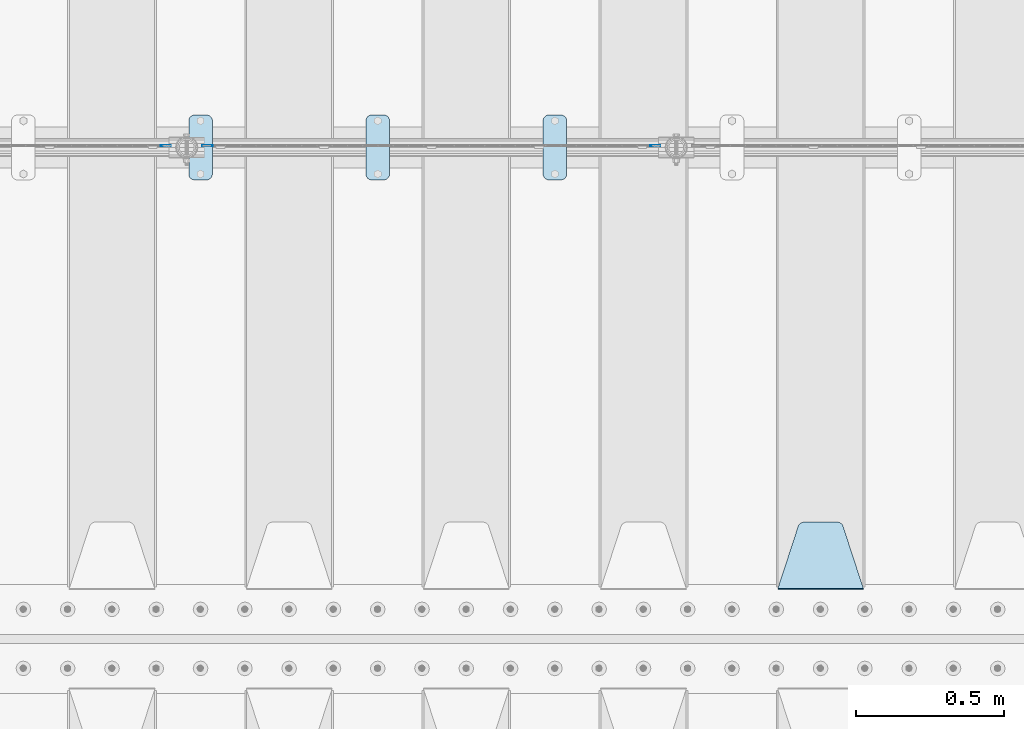
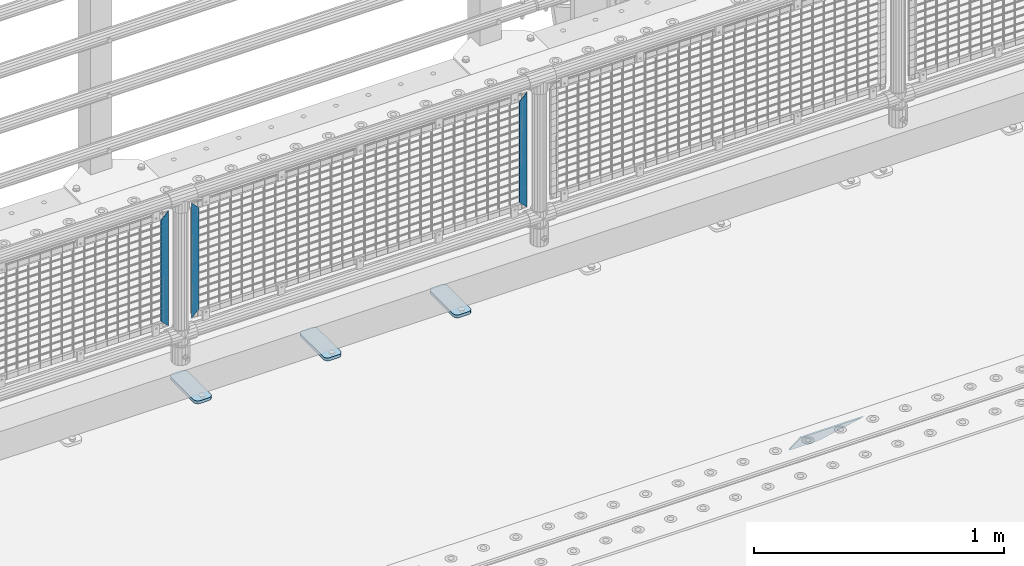
# One storey, part 172 of 193: 7 plates.
"""IFC2X3 building model written with IfcOpenShell, lengths in millimetres."""

from ifc_helpers import new_model, si_unit, frame, origin_with_axes, place, context, subcontext, project, spatial, faceted_brep, material, type_object, element, save


model = new_model("IFC2X3")

# Units and contexts
model_context = context("Model", 3, precision=1e-05, world=origin_with_axes())
body_context = subcontext(model_context, "Body", "Model", "MODEL_VIEW")
ifc_project = project(units=[si_unit("LENGTHUNIT", "METRE", prefix="MILLI"), si_unit("AREAUNIT", "SQUARE_METRE"), si_unit("VOLUMEUNIT", "CUBIC_METRE"), si_unit("MASSUNIT", "GRAM", prefix="KILO"), si_unit("TIMEUNIT", "SECOND"), si_unit("PLANEANGLEUNIT", "RADIAN"), si_unit("SOLIDANGLEUNIT", "STERADIAN"), si_unit("THERMODYNAMICTEMPERATUREUNIT", "DEGREE_CELSIUS"), si_unit("LUMINOUSINTENSITYUNIT", "LUMEN")], contexts=[model_context])

# Site, building, storey
site_placement = place(None, origin_with_axes())
site = spatial("IfcSite", under=ifc_project, at=site_placement, CompositionType="ELEMENT")
building_placement = place(site_placement, origin_with_axes())
building = spatial("IfcBuilding", under=site, at=building_placement, Name="Standard", CompositionType="ELEMENT")
storey_placement = place(building_placement, origin_with_axes())
storey = spatial("IfcBuildingStorey", under=building, at=storey_placement, Name="Undefined", CompositionType="ELEMENT", Elevation=0.0)

# Plates
ifc_material_1 = material(Name="STEEL/S355N")
plate_type_1 = type_object("IfcPlateType", PredefinedType="NOTDEFINED")
plate_1_placement = place(storey_placement, frame((-32905.0, 27168.232233047, -1.76776695296758), z_axis=(0.0, 0.707106781186547, -0.707106781186548), x_axis=(-1.0, 0.0, 0.0)))
element("IfcPlate", 1, at=plate_1_placement, inside=storey, type_object=plate_type_1, material=ifc_material_1, context=body_context, shape_type="Brep", body=[
    faceted_brep([(0.0, -2.5, 0.0), (69.345504679477, -2.50000000000364, 300.171731424831), (69.345504679477, 2.49999999999636, 300.171731424831), (0.0, 2.5, 0.0), (70.9274061199576, -2.50000000000364, 304.897442415397), (70.9274061199576, 2.49999999999636, 304.897442415397), (73.3818627772307, -2.50000000000364, 309.234538108529), (73.3818627772307, 2.49999999999636, 309.234538108529), (76.6187032999551, -2.50000000000728, 313.023683126103), (76.6187032999551, 2.49999999999636, 313.023683126103), (80.5190132704993, -2.50000000000364, 316.125672595372), (80.5190132704993, 2.49999999999636, 316.125672595368), (84.9395038596849, -2.50000000000364, 318.426546230472), (84.9395038596849, 2.49999999999636, 318.426546230476), (89.7177759439219, -2.50000000000364, 319.841774983273), (89.7177759439219, 2.49999999999636, 319.841774983277), (94.678286292652, -2.50000000000364, 320.319366455074), (94.678286292652, 2.49999999999636, 320.319366455074), (195.321713707348, -2.50000000000364, 320.319366455074), (195.321713707348, 2.49999999999636, 320.319366455074), (200.282224056078, -2.50000000000364, 319.841774983273), (200.282224056078, 2.49999999999636, 319.841774983277), (205.060496140315, -2.50000000000364, 318.426546230472), (205.060496140315, 2.49999999999636, 318.426546230472), (209.480986729501, -2.50000000000364, 316.125672595372), (209.480986729501, 2.49999999999636, 316.125672595368), (213.381296700045, -2.50000000000728, 313.023683126103), (213.381296700045, 2.49999999999272, 313.023683126103), (216.618137222769, -2.50000000000364, 309.234538108525), (216.618137222769, 2.49999999999636, 309.234538108522), (219.072593880042, -2.50000000000364, 304.897442415397), (219.072593880042, 2.49999999999636, 304.897442415397), (220.654495320523, -2.50000000000364, 300.171731424831), (220.654495320523, 2.49999999999636, 300.171731424831), (290.0, -2.50000000000364, 0.0), (290.0, 2.49999999999636, 0.0)], [[[0, 1, 2, 3]], [[1, 4, 5, 2]], [[4, 6, 7, 5]], [[6, 8, 9, 7]], [[8, 10, 11, 9]], [[10, 12, 13, 11]], [[12, 14, 15, 13]], [[14, 16, 17, 15]], [[16, 18, 19, 17]], [[18, 20, 21, 19]], [[20, 22, 23, 21]], [[22, 24, 25, 23]], [[24, 26, 27, 25]], [[26, 28, 29, 27]], [[28, 30, 31, 29]], [[30, 32, 33, 31]], [[32, 34, 35, 33]], [[34, 0, 3, 35]], [[5, 7, 9, 11, 13, 15, 17, 19, 21, 23, 25, 27, 29, 31, 33, 35, 3, 2]], [[34, 32, 30, 28, 26, 24, 22, 20, 18, 16, 14, 12, 10, 8, 6, 4, 1, 0]]]),
])
ifc_material_2 = material(Name="Misc_Undefined")
plate_type_2 = type_object("IfcPlateType", PredefinedType="NOTDEFINED")
plate_2_placement = place(storey_placement, frame((-35108.490286459, 28670.5, 879.519963133601), z_axis=(-0.707008801899319, 0.0, -0.707204746899291), x_axis=(-0.70720474689929, 0.0, 0.707008801899319)))
element("IfcPlate", 2, at=plate_2_placement, inside=storey, type_object=plate_type_2, material=ifc_material_2, context=body_context, shape_type="Brep", body=[
    faceted_brep([(0.0, -1.49999999999636, 3.63797880709171e-12), (-348.552185058594, -1.5, 348.655029296875), (-348.552185058594, 1.5, 348.655029296875), (0.0, 1.50000000000364, 7.27595761418343e-12), (-348.544891357422, -1.5, 398.152496337891), (-348.544891357422, 1.5, 398.152496337891), (49.50439453125, -1.5, 7.6397554948926e-11), (49.50439453125, 1.5, 7.6397554948926e-11)], [[[0, 1, 2, 3]], [[1, 4, 5, 2]], [[4, 6, 7, 5]], [[6, 0, 3, 7]], [[5, 7, 3, 2]], [[6, 4, 1, 0]]]),
])
for number, where, z_axis, x_axis in (
    (3, (-33627.5003125164, 28670.5, 879.52), (0.707103624179499, 0.0, -0.707109938179501), (0.707109938179495, 0.0, 0.707103624179505)),
    (4, (-35285.5003125164, 28670.5, 879.52), (0.707103624179499, 0.0, -0.707109938179501), (0.707109938179495, 0.0, 0.707103624179505)),
):
    element("IfcPlate", number, at=place(storey_placement, frame(where, z_axis=z_axis, x_axis=x_axis)), inside=storey, type_object=plate_type_2, material=ifc_material_2, context=body_context, shape_type="Brep", body=[
        faceted_brep([(0.0, -1.49999999999636, 3.63797880709171e-12), (-348.605163574215, -1.5, 348.602081298824), (-348.605163574215, 1.5, 348.602081298824), (0.0, 1.50000000000364, 7.27595761418343e-12), (-348.605163574215, -1.5, 398.099334716793), (-348.605163574215, 1.5, 398.099334716793), (49.4976959228552, -1.5, -1.01863406598568e-10), (49.4976959228552, 1.5, -1.01863406598568e-10)], [[[0, 1, 2, 3]], [[1, 4, 5, 2]], [[4, 6, 7, 5]], [[6, 0, 3, 7]], [[5, 7, 3, 2]], [[6, 4, 1, 0]]]),
    ])
ifc_material_3 = material(Name="STEEL/S355J2")
plate_type_3 = type_object("IfcPlateType", PredefinedType="NOTDEFINED")
plate_3_placement = place(storey_placement, frame((-33990.0, 28774.5, 21.0199999999977), z_axis=(1.0, 0.0, 0.0), x_axis=(0.0, -1.0, 0.0)))
element("IfcPlate", 5, at=plate_3_placement, inside=storey, type_object=plate_type_3, material=ifc_material_3, context=body_context, shape_type="Brep", body=[
    faceted_brep([(0.0, -7.0, 20.0), (0.0, -7.0, 60.0), (0.0, 7.0, 60.0), (0.0, 7.0, 20.0), (0.384294391937146, -7.0, 63.9018064403208), (0.384294391937146, 7.0, 63.9018064403208), (1.52240934977453, -7.0, 67.6536686473009), (1.52240934977453, 7.0, 67.6536686473009), (3.37060775395003, -7.0, 71.1114046603907), (3.37060775395003, 7.0, 71.1114046603907), (5.8578643762703, -7.0, 74.1421356237297), (5.8578643762703, 7.0, 74.1421356237297), (8.88859533960931, -7.0, 76.62939224605), (8.88859533960931, 7.0, 76.62939224605), (12.3463313526991, -7.0, 78.4775906502255), (12.3463313526991, 7.0, 78.4775906502255), (16.0981935596792, -7.0, 79.6157056080629), (16.0981935596792, 7.0, 79.6157056080629), (20.0, -7.0, 80.0), (20.0, 7.0, 80.0), (200.0, -7.0, 80.0), (200.0, 7.0, 80.0), (203.901806440321, -7.0, 79.6157056080629), (203.901806440321, 7.0, 79.6157056080629), (207.653668647301, -7.0, 78.4775906502255), (207.653668647301, 7.0, 78.4775906502255), (211.111404660391, -7.0, 76.62939224605), (211.111404660391, 7.0, 76.62939224605), (214.14213562373, -7.0, 74.1421356237297), (214.14213562373, 7.0, 74.1421356237297), (216.62939224605, -7.0, 71.1114046603907), (216.62939224605, 7.0, 71.1114046603907), (218.477590650225, -7.0, 67.6536686473009), (218.477590650225, 7.0, 67.6536686473009), (219.615705608063, -7.0, 63.9018064403208), (219.615705608063, 7.0, 63.9018064403208), (220.0, -7.0, 60.0), (220.0, 7.0, 60.0), (220.0, -7.0, 20.0), (220.0, 7.0, 20.0), (219.615705608063, -7.0, 16.0981935596792), (219.615705608063, 7.0, 16.0981935596792), (218.477590650225, -7.0, 12.3463313526991), (218.477590650225, 7.0, 12.3463313526991), (216.62939224605, -7.0, 8.88859533960931), (216.62939224605, 7.0, 8.88859533960931), (214.14213562373, -7.0, 5.8578643762703), (214.14213562373, 7.0, 5.8578643762703), (211.111404660391, -7.0, 3.37060775395003), (211.111404660391, 7.0, 3.37060775395003), (207.653668647301, -7.0, 1.52240934977453), (207.653668647301, 7.0, 1.52240934977453), (203.901806440321, -7.0, 0.384294391937146), (203.901806440321, 7.0, 0.384294391937146), (200.0, -7.0, 0.0), (200.0, 7.0, 0.0), (20.0, -7.0, 0.0), (20.0, 7.0, 0.0), (16.0981935596792, -7.0, 0.384294391937146), (16.0981935596792, 7.0, 0.384294391937146), (12.3463313526991, -7.0, 1.52240934977453), (12.3463313526991, 7.0, 1.52240934977453), (8.88859533960931, -7.0, 3.37060775395003), (8.88859533960931, 7.0, 3.37060775395003), (5.8578643762703, -7.0, 5.8578643762703), (5.8578643762703, 7.0, 5.8578643762703), (3.37060775395003, -7.0, 8.88859533960931), (3.37060775395003, 7.0, 8.88859533960931), (1.52240934977453, -7.0, 12.3463313526991), (1.52240934977453, 7.0, 12.3463313526991), (0.384294391937146, -7.0, 16.0981935596792), (0.384294391937146, 7.0, 16.0981935596792)], [[[0, 1, 2, 3]], [[1, 4, 5, 2]], [[4, 6, 7, 5]], [[6, 8, 9, 7]], [[8, 10, 11, 9]], [[10, 12, 13, 11]], [[12, 14, 15, 13]], [[14, 16, 17, 15]], [[16, 18, 19, 17]], [[18, 20, 21, 19]], [[20, 22, 23, 21]], [[22, 24, 25, 23]], [[24, 26, 27, 25]], [[26, 28, 29, 27]], [[28, 30, 31, 29]], [[30, 32, 33, 31]], [[32, 34, 35, 33]], [[34, 36, 37, 35]], [[36, 38, 39, 37]], [[38, 40, 41, 39]], [[40, 42, 43, 41]], [[42, 44, 45, 43]], [[44, 46, 47, 45]], [[46, 48, 49, 47]], [[48, 50, 51, 49]], [[50, 52, 53, 51]], [[52, 54, 55, 53]], [[54, 56, 57, 55]], [[56, 58, 59, 57]], [[58, 60, 61, 59]], [[60, 62, 63, 61]], [[62, 64, 65, 63]], [[64, 66, 67, 65]], [[66, 68, 69, 67]], [[68, 70, 71, 69]], [[70, 0, 3, 71]], [[5, 7, 9, 11, 13, 15, 17, 19, 21, 23, 25, 27, 29, 31, 33, 35, 37, 39, 41, 43, 45, 47, 49, 51, 53, 55, 57, 59, 61, 63, 65, 67, 69, 71, 3, 2]], [[70, 68, 66, 64, 62, 60, 58, 56, 54, 52, 50, 48, 46, 44, 42, 40, 38, 36, 34, 32, 30, 28, 26, 24, 22, 20, 18, 16, 14, 12, 10, 8, 6, 4, 1, 0]]]),
])
plate_4_placement = place(storey_placement, frame((-34590.0, 28774.5, 21.0199999999977), z_axis=(1.0, 0.0, 0.0), x_axis=(0.0, -1.0, 0.0)))
element("IfcPlate", 6, at=plate_4_placement, inside=storey, type_object=plate_type_3, material=ifc_material_3, context=body_context, shape_type="Brep", body=[
    faceted_brep([(0.0, -7.0, 20.0), (0.0, -7.0, 60.0), (0.0, 7.0, 60.0), (0.0, 7.0, 20.0), (0.384294391937146, -7.0, 63.9018064403208), (0.384294391937146, 7.0, 63.9018064403208), (1.52240934977453, -7.0, 67.6536686473009), (1.52240934977453, 7.0, 67.6536686473009), (3.37060775395003, -7.0, 71.1114046603907), (3.37060775395003, 7.0, 71.1114046603907), (5.8578643762703, -7.0, 74.1421356237297), (5.8578643762703, 7.0, 74.1421356237297), (8.88859533960931, -7.0, 76.62939224605), (8.88859533960931, 7.0, 76.62939224605), (12.3463313526991, -7.0, 78.4775906502255), (12.3463313526991, 7.0, 78.4775906502255), (16.0981935596792, -7.0, 79.6157056080629), (16.0981935596792, 7.0, 79.6157056080629), (20.0, -7.0, 80.0), (20.0, 7.0, 80.0), (200.0, -7.0, 80.0), (200.0, 7.0, 80.0), (203.901806440321, -7.0, 79.6157056080629), (203.901806440321, 7.0, 79.6157056080629), (207.653668647301, -7.0, 78.4775906502255), (207.653668647301, 7.0, 78.4775906502255), (211.111404660391, -7.0, 76.62939224605), (211.111404660391, 7.0, 76.62939224605), (214.14213562373, -7.0, 74.1421356237297), (214.14213562373, 7.0, 74.1421356237297), (216.62939224605, -7.0, 71.1114046603907), (216.62939224605, 7.0, 71.1114046603907), (218.477590650225, -7.0, 67.6536686473009), (218.477590650225, 7.0, 67.6536686473009), (219.615705608063, -7.0, 63.9018064403208), (219.615705608063, 7.0, 63.9018064403208), (220.0, -7.0, 60.0), (220.0, 7.0, 60.0), (220.0, -7.0, 20.0), (220.0, 7.0, 20.0), (219.615705608063, -7.0, 16.0981935596792), (219.615705608063, 7.0, 16.0981935596792), (218.477590650225, -7.0, 12.3463313526991), (218.477590650225, 7.0, 12.3463313526991), (216.62939224605, -7.0, 8.88859533960931), (216.62939224605, 7.0, 8.88859533960931), (214.14213562373, -7.0, 5.8578643762703), (214.14213562373, 7.0, 5.8578643762703), (211.111404660391, -7.0, 3.37060775395003), (211.111404660391, 7.0, 3.37060775395003), (207.653668647301, -7.0, 1.52240934977453), (207.653668647301, 7.0, 1.52240934977453), (203.901806440321, -7.0, 0.384294391937146), (203.901806440321, 7.0, 0.384294391937146), (200.0, -7.0, 0.0), (200.0, 7.0, 0.0), (20.0, -7.0, 0.0), (20.0, 7.0, 0.0), (16.0981935596792, -7.0, 0.384294391937146), (16.0981935596792, 7.0, 0.384294391937146), (12.3463313526991, -7.0, 1.52240934977453), (12.3463313526991, 7.0, 1.52240934977453), (8.88859533960931, -7.0, 3.37060775395003), (8.88859533960931, 7.0, 3.37060775395003), (5.8578643762703, -7.0, 5.8578643762703), (5.8578643762703, 7.0, 5.8578643762703), (3.37060775395003, -7.0, 8.88859533960931), (3.37060775395003, 7.0, 8.88859533960931), (1.52240934977453, -7.0, 12.3463313526991), (1.52240934977453, 7.0, 12.3463313526991), (0.384294391937146, -7.0, 16.0981935596792), (0.384294391937146, 7.0, 16.0981935596792)], [[[0, 1, 2, 3]], [[1, 4, 5, 2]], [[4, 6, 7, 5]], [[6, 8, 9, 7]], [[8, 10, 11, 9]], [[10, 12, 13, 11]], [[12, 14, 15, 13]], [[14, 16, 17, 15]], [[16, 18, 19, 17]], [[18, 20, 21, 19]], [[20, 22, 23, 21]], [[22, 24, 25, 23]], [[24, 26, 27, 25]], [[26, 28, 29, 27]], [[28, 30, 31, 29]], [[30, 32, 33, 31]], [[32, 34, 35, 33]], [[34, 36, 37, 35]], [[36, 38, 39, 37]], [[38, 40, 41, 39]], [[40, 42, 43, 41]], [[42, 44, 45, 43]], [[44, 46, 47, 45]], [[46, 48, 49, 47]], [[48, 50, 51, 49]], [[50, 52, 53, 51]], [[52, 54, 55, 53]], [[54, 56, 57, 55]], [[56, 58, 59, 57]], [[58, 60, 61, 59]], [[60, 62, 63, 61]], [[62, 64, 65, 63]], [[64, 66, 67, 65]], [[66, 68, 69, 67]], [[68, 70, 71, 69]], [[70, 0, 3, 71]], [[5, 7, 9, 11, 13, 15, 17, 19, 21, 23, 25, 27, 29, 31, 33, 35, 37, 39, 41, 43, 45, 47, 49, 51, 53, 55, 57, 59, 61, 63, 65, 67, 69, 71, 3, 2]], [[70, 68, 66, 64, 62, 60, 58, 56, 54, 52, 50, 48, 46, 44, 42, 40, 38, 36, 34, 32, 30, 28, 26, 24, 22, 20, 18, 16, 14, 12, 10, 8, 6, 4, 1, 0]]]),
])
plate_5_placement = place(storey_placement, frame((-35190.0, 28774.5, 21.0199999999977), z_axis=(1.0, 0.0, 0.0), x_axis=(0.0, -1.0, 0.0)))
element("IfcPlate", 7, at=plate_5_placement, inside=storey, type_object=plate_type_3, material=ifc_material_3, context=body_context, shape_type="Brep", body=[
    faceted_brep([(0.0, -7.0, 20.0), (0.0, -7.0, 60.0), (0.0, 7.0, 60.0), (0.0, 7.0, 20.0), (0.384294391937146, -7.0, 63.9018064403208), (0.384294391937146, 7.0, 63.9018064403208), (1.52240934977453, -7.0, 67.6536686473009), (1.52240934977453, 7.0, 67.6536686473009), (3.37060775395003, -7.0, 71.1114046603907), (3.37060775395003, 7.0, 71.1114046603907), (5.8578643762703, -7.0, 74.1421356237297), (5.8578643762703, 7.0, 74.1421356237297), (8.88859533960931, -7.0, 76.62939224605), (8.88859533960931, 7.0, 76.62939224605), (12.3463313526991, -7.0, 78.4775906502255), (12.3463313526991, 7.0, 78.4775906502255), (16.0981935596792, -7.0, 79.6157056080629), (16.0981935596792, 7.0, 79.6157056080629), (20.0, -7.0, 80.0), (20.0, 7.0, 80.0), (200.0, -7.0, 80.0), (200.0, 7.0, 80.0), (203.901806440321, -7.0, 79.6157056080629), (203.901806440321, 7.0, 79.6157056080629), (207.653668647301, -7.0, 78.4775906502255), (207.653668647301, 7.0, 78.4775906502255), (211.111404660391, -7.0, 76.62939224605), (211.111404660391, 7.0, 76.62939224605), (214.14213562373, -7.0, 74.1421356237297), (214.14213562373, 7.0, 74.1421356237297), (216.62939224605, -7.0, 71.1114046603907), (216.62939224605, 7.0, 71.1114046603907), (218.477590650225, -7.0, 67.6536686473009), (218.477590650225, 7.0, 67.6536686473009), (219.615705608063, -7.0, 63.9018064403208), (219.615705608063, 7.0, 63.9018064403208), (220.0, -7.0, 60.0), (220.0, 7.0, 60.0), (220.0, -7.0, 20.0), (220.0, 7.0, 20.0), (219.615705608063, -7.0, 16.0981935596792), (219.615705608063, 7.0, 16.0981935596792), (218.477590650225, -7.0, 12.3463313526991), (218.477590650225, 7.0, 12.3463313526991), (216.62939224605, -7.0, 8.88859533960931), (216.62939224605, 7.0, 8.88859533960931), (214.14213562373, -7.0, 5.8578643762703), (214.14213562373, 7.0, 5.8578643762703), (211.111404660391, -7.0, 3.37060775395003), (211.111404660391, 7.0, 3.37060775395003), (207.653668647301, -7.0, 1.52240934977453), (207.653668647301, 7.0, 1.52240934977453), (203.901806440321, -7.0, 0.384294391937146), (203.901806440321, 7.0, 0.384294391937146), (200.0, -7.0, 0.0), (200.0, 7.0, 0.0), (20.0, -7.0, 0.0), (20.0, 7.0, 0.0), (16.0981935596792, -7.0, 0.384294391937146), (16.0981935596792, 7.0, 0.384294391937146), (12.3463313526991, -7.0, 1.52240934977453), (12.3463313526991, 7.0, 1.52240934977453), (8.88859533960931, -7.0, 3.37060775395003), (8.88859533960931, 7.0, 3.37060775395003), (5.8578643762703, -7.0, 5.8578643762703), (5.8578643762703, 7.0, 5.8578643762703), (3.37060775395003, -7.0, 8.88859533960931), (3.37060775395003, 7.0, 8.88859533960931), (1.52240934977453, -7.0, 12.3463313526991), (1.52240934977453, 7.0, 12.3463313526991), (0.384294391937146, -7.0, 16.0981935596792), (0.384294391937146, 7.0, 16.0981935596792)], [[[0, 1, 2, 3]], [[1, 4, 5, 2]], [[4, 6, 7, 5]], [[6, 8, 9, 7]], [[8, 10, 11, 9]], [[10, 12, 13, 11]], [[12, 14, 15, 13]], [[14, 16, 17, 15]], [[16, 18, 19, 17]], [[18, 20, 21, 19]], [[20, 22, 23, 21]], [[22, 24, 25, 23]], [[24, 26, 27, 25]], [[26, 28, 29, 27]], [[28, 30, 31, 29]], [[30, 32, 33, 31]], [[32, 34, 35, 33]], [[34, 36, 37, 35]], [[36, 38, 39, 37]], [[38, 40, 41, 39]], [[40, 42, 43, 41]], [[42, 44, 45, 43]], [[44, 46, 47, 45]], [[46, 48, 49, 47]], [[48, 50, 51, 49]], [[50, 52, 53, 51]], [[52, 54, 55, 53]], [[54, 56, 57, 55]], [[56, 58, 59, 57]], [[58, 60, 61, 59]], [[60, 62, 63, 61]], [[62, 64, 65, 63]], [[64, 66, 67, 65]], [[66, 68, 69, 67]], [[68, 70, 71, 69]], [[70, 0, 3, 71]], [[5, 7, 9, 11, 13, 15, 17, 19, 21, 23, 25, 27, 29, 31, 33, 35, 37, 39, 41, 43, 45, 47, 49, 51, 53, 55, 57, 59, 61, 63, 65, 67, 69, 71, 3, 2]], [[70, 68, 66, 64, 62, 60, 58, 56, 54, 52, 50, 48, 46, 44, 42, 40, 38, 36, 34, 32, 30, 28, 26, 24, 22, 20, 18, 16, 14, 12, 10, 8, 6, 4, 1, 0]]]),
])

save(model, "model.ifc")
